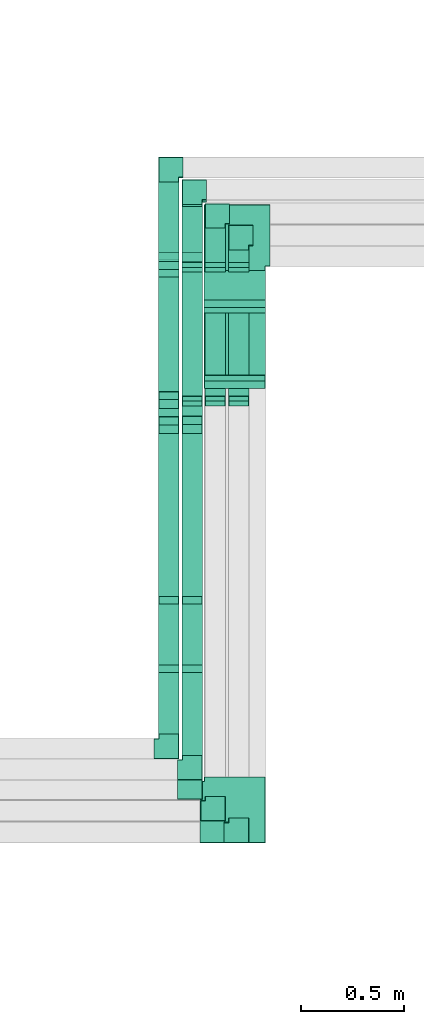
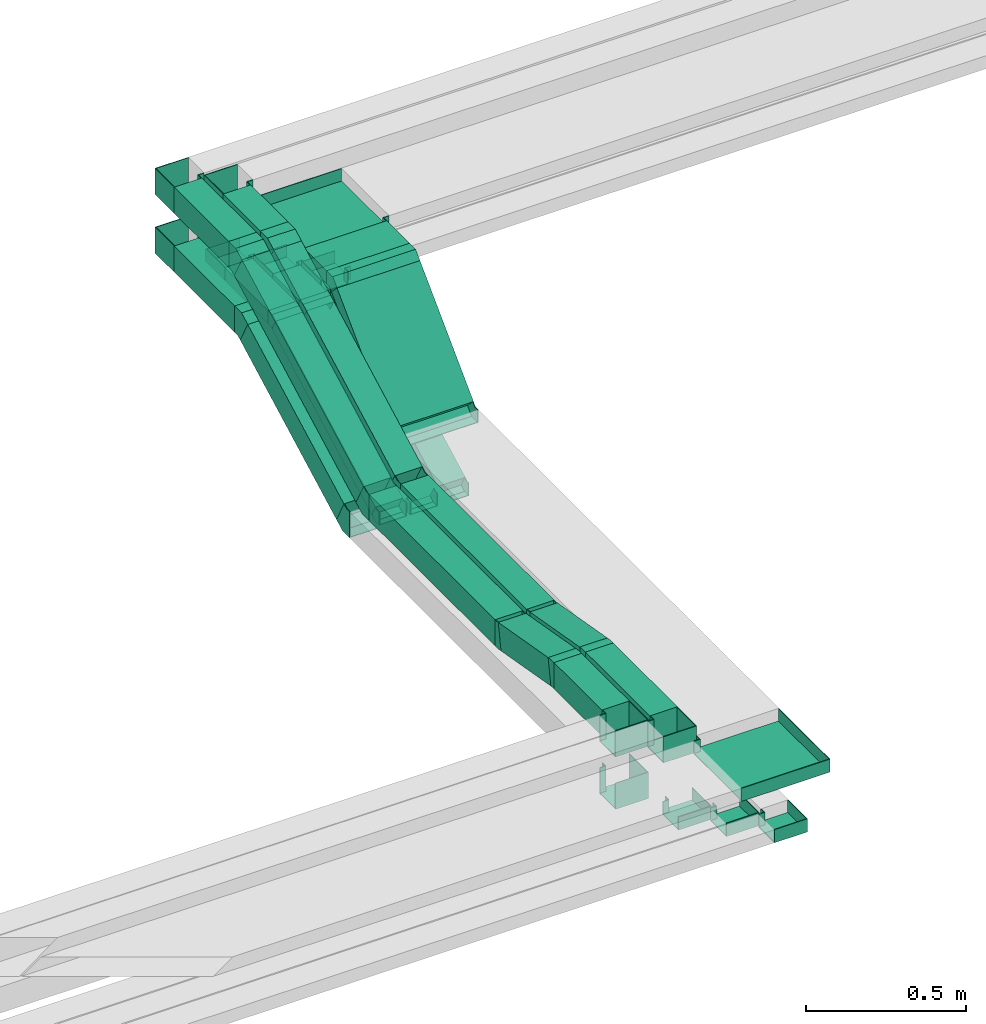
# One storey, part 9 of 14: 32 flow fittings, 20 flow segments.
"""IFC2X3 building model written with IfcOpenShell, lengths in millimetres."""

from ifc_helpers import new_model, entity, si_unit, converted_unit, derived_unit, direction, frame, frame_2d, origin, origin_2d_with_axis, place, context, subcontext, project, spatial, rectangle, extrude, faceted_brep, source, transform, mapped, material, type_object, type_shapes, element, save


model = new_model("IFC2X3")

# Units and contexts
model_context = context("Model", 3, precision=0.01, world=origin(), true_north=direction((6.12303176911189e-17, 1.0)))
body_context = subcontext(model_context, "Body", "Model", "MODEL_VIEW")
ifc_project = project(units=[si_unit("LENGTHUNIT", "METRE", prefix="MILLI"), si_unit("AREAUNIT", "SQUARE_METRE"), si_unit("VOLUMEUNIT", "CUBIC_METRE"), converted_unit("PLANEANGLEUNIT", "DEGREE", entity("IfcRatioMeasure", 0.0174532925199433), si_unit("PLANEANGLEUNIT", "RADIAN"), dimensions=[0, 0, 0, 0, 0, 0, 0]), si_unit("MASSUNIT", "GRAM", prefix="KILO"), derived_unit("MASSDENSITYUNIT", [(si_unit("MASSUNIT", "GRAM", prefix="KILO"), 1), (si_unit("LENGTHUNIT", "METRE"), -3)]), derived_unit("MOMENTOFINERTIAUNIT", [(si_unit("LENGTHUNIT", "METRE"), 4)]), si_unit("TIMEUNIT", "SECOND"), si_unit("FREQUENCYUNIT", "HERTZ"), si_unit("THERMODYNAMICTEMPERATUREUNIT", "DEGREE_CELSIUS"), derived_unit("THERMALTRANSMITTANCEUNIT", [(si_unit("MASSUNIT", "GRAM", prefix="KILO"), 1), (si_unit("THERMODYNAMICTEMPERATUREUNIT", "KELVIN"), -1), (si_unit("TIMEUNIT", "SECOND"), -3)]), derived_unit("VOLUMETRICFLOWRATEUNIT", [(si_unit("LENGTHUNIT", "METRE"), 3), (si_unit("TIMEUNIT", "SECOND"), -1)]), derived_unit("MASSFLOWRATEUNIT", [(si_unit("MASSUNIT", "GRAM", prefix="KILO"), 1), (si_unit("TIMEUNIT", "SECOND"), -1)]), derived_unit("ROTATIONALFREQUENCYUNIT", [(si_unit("TIMEUNIT", "SECOND"), -1)]), si_unit("ELECTRICCURRENTUNIT", "AMPERE"), si_unit("ELECTRICVOLTAGEUNIT", "VOLT"), si_unit("POWERUNIT", "WATT"), si_unit("FORCEUNIT", "NEWTON", prefix="KILO"), si_unit("ILLUMINANCEUNIT", "LUX"), si_unit("LUMINOUSFLUXUNIT", "LUMEN"), si_unit("LUMINOUSINTENSITYUNIT", "CANDELA"), derived_unit("USERDEFINED", [(si_unit("MASSUNIT", "GRAM", prefix="KILO"), -1), (si_unit("LENGTHUNIT", "METRE"), -2), (si_unit("TIMEUNIT", "SECOND"), 3), (si_unit("LUMINOUSFLUXUNIT", "LUMEN"), 1)]), derived_unit("LINEARVELOCITYUNIT", [(si_unit("LENGTHUNIT", "METRE"), 1), (si_unit("TIMEUNIT", "SECOND"), -1)]), si_unit("PRESSUREUNIT", "PASCAL"), derived_unit("USERDEFINED", [(si_unit("LENGTHUNIT", "METRE"), -2), (si_unit("MASSUNIT", "GRAM", prefix="KILO"), 1), (si_unit("TIMEUNIT", "SECOND"), -2)]), derived_unit("LINEARFORCEUNIT", [(si_unit("MASSUNIT", "GRAM", prefix="KILO"), 1), (si_unit("LENGTHUNIT", "METRE"), 1), (si_unit("TIMEUNIT", "SECOND"), -2), (si_unit("LENGTHUNIT", "METRE"), -1)]), derived_unit("PLANARFORCEUNIT", [(si_unit("MASSUNIT", "GRAM", prefix="KILO"), 1), (si_unit("LENGTHUNIT", "METRE"), 1), (si_unit("TIMEUNIT", "SECOND"), -2), (si_unit("LENGTHUNIT", "METRE"), -2)])], contexts=[model_context])

# Site, building, storey
site_placement = place(None, origin())
site = spatial("IfcSite", under=ifc_project, at=site_placement, CompositionType="ELEMENT")
building_placement = place(site_placement, origin())
building = spatial("IfcBuilding", under=site, at=building_placement, CompositionType="ELEMENT")
storey_placement = place(building_placement, frame((0.0, 0.0, 19800.0)))
storey = spatial("IfcBuildingStorey", under=building, at=storey_placement, Name="06", CompositionType="ELEMENT", Elevation=19800.0)

# Flow segments
cable_carrier_segment_type = type_object("IfcCableCarrierSegmentType", PredefinedType="CABLETRAYSEGMENT")
flow_segment_1_placement = place(storey_placement, frame((45595.12, 8738.58, 2760.53)))
element("IfcFlowSegment", 1, at=flow_segment_1_placement, inside=storey, type_object=cable_carrier_segment_type, context=body_context, shape_type="SweptSolid", body=[
    extrude(rectangle(XDim=100.000000000004, YDim=99.9999999999946, at=origin_2d_with_axis()), frame((50.0, 23.5, 44.14), z_axis=(0.0, 0.882701442604095, 0.469934211592058), x_axis=(0.0, -0.469934211592058, 0.882701442604095)), (0.0, 0.0, 1.0), 863.244153807607),
])
flow_segment_2_placement = place(storey_placement, frame((45595.12, 7913.71, 2740.0)))
element("IfcFlowSegment", 2, at=flow_segment_2_placement, inside=storey, type_object=cable_carrier_segment_type, context=body_context, shape_type="SweptSolid", body=[
    extrude(rectangle(XDim=789.605024897989, YDim=99.9999999999946, at=origin_2d_with_axis()), frame((50.0, 394.8, 0.0), z_axis=(0.0, 0.0, 1.0), x_axis=(0.0, 1.0, 0.0)), (0.0, 0.0, 1.0), 100.000000000003),
])
flow_segment_3_placement = place(storey_placement, frame((45595.12, 7564.54, 2743.22)))
element("IfcFlowSegment", 3, at=flow_segment_3_placement, inside=storey, type_object=cable_carrier_segment_type, context=body_context, shape_type="SweptSolid", body=[
    extrude(rectangle(XDim=99.9999999999979, YDim=99.9999999999946, at=origin_2d_with_axis()), frame((50.0, 8.68, 104.31), z_axis=(0.0, 0.984807753012211, -0.173648177666916), x_axis=(0.0, 0.173648177666916, 0.984807753012211)), (0.0, 0.0, 1.0), 317.153609648687),
])
flow_segment_4_placement = place(storey_placement, frame((45595.12, 7245.0, 2800.0)))
element("IfcFlowSegment", 4, at=flow_segment_4_placement, inside=storey, type_object=cable_carrier_segment_type, context=body_context, shape_type="SweptSolid", body=[
    extrude(rectangle(XDim=300.062822927531, YDim=99.9999999999946, at=origin_2d_with_axis()), frame((50.0, 150.03, 0.0), z_axis=(0.0, 0.0, 1.0), x_axis=(0.0, -1.0, 0.0)), (0.0, 0.0, 1.0), 100.000000000003),
])
flow_segment_5_placement = place(storey_placement, frame((45709.29, 8740.22, 2761.4)))
element("IfcFlowSegment", 5, at=flow_segment_5_placement, inside=storey, type_object=cable_carrier_segment_type, context=body_context, shape_type="SweptSolid", body=[
    extrude(rectangle(XDim=100.000000000004, YDim=99.9999999999946, at=origin_2d_with_axis()), frame((50.0, 23.5, 44.14), z_axis=(0.0, 0.882701442604095, 0.469934211592058), x_axis=(0.0, -0.469934211592058, 0.882701442604095)), (0.0, 0.0, 1.0), 859.53337394256),
])
flow_segment_6_placement = place(storey_placement, frame((45709.29, 7913.71, 2740.0)))
element("IfcFlowSegment", 6, at=flow_segment_6_placement, inside=storey, type_object=cable_carrier_segment_type, context=body_context, shape_type="SweptSolid", body=[
    extrude(rectangle(XDim=789.803925423303, YDim=99.9999999999946, at=origin_2d_with_axis()), frame((50.0, 394.9, 0.0), z_axis=(0.0, 0.0, 1.0), x_axis=(0.0, 1.0, 0.0)), (0.0, 0.0, 1.0), 100.000000000003),
])
flow_segment_7_placement = place(storey_placement, frame((45709.29, 7564.54, 2743.22)))
element("IfcFlowSegment", 7, at=flow_segment_7_placement, inside=storey, type_object=cable_carrier_segment_type, context=body_context, shape_type="SweptSolid", body=[
    extrude(rectangle(XDim=99.9999999999979, YDim=99.9999999999946, at=origin_2d_with_axis()), frame((50.0, 8.68, 104.31), z_axis=(0.0, 0.984807753012211, -0.173648177666916), x_axis=(0.0, 0.173648177666916, 0.984807753012211)), (0.0, 0.0, 1.0), 317.153609648693),
])
flow_segment_8_placement = place(storey_placement, frame((45709.29, 7141.93, 2800.0)))
element("IfcFlowSegment", 8, at=flow_segment_8_placement, inside=storey, type_object=cable_carrier_segment_type, context=body_context, shape_type="SweptSolid", body=[
    extrude(rectangle(XDim=403.134642804848, YDim=99.9999999999946, at=origin_2d_with_axis()), frame((50.0, 201.57, 0.0), z_axis=(0.0, 0.0, 1.0), x_axis=(0.0, -1.0, 0.0)), (0.0, 0.0, 1.0), 100.000000000003),
])
flow_segment_9_placement = place(storey_placement, frame((45816.39, 8951.97, 2826.97)))
element("IfcFlowSegment", 9, at=flow_segment_9_placement, inside=storey, type_object=cable_carrier_segment_type, context=body_context, shape_type="SweptSolid", body=[
    extrude(rectangle(XDim=50.0000000000018, YDim=300.000000000001, at=origin_2d_with_axis()), frame((150.0, 17.68, 17.68), z_axis=(-1.65086776189245e-09, 0.707106781186548, 0.707106781186548), x_axis=(1.34656693262509e-09, -0.707106781186548, 0.707106781186548)), (0.0, 0.0, 1.0), 474.766610138279),
])
flow_segment_10_placement = place(storey_placement, frame((45595.12, 9546.18, 2950.0)))
element("IfcFlowSegment", 10, at=flow_segment_10_placement, inside=storey, type_object=cable_carrier_segment_type, context=body_context, shape_type="SweptSolid", body=[
    extrude(rectangle(XDim=378.820559701483, YDim=99.9999999999946, at=origin_2d_with_axis()), frame((50.0, 189.41, 0.0), z_axis=(0.0, 0.0, 1.0), x_axis=(0.0, -1.0, 0.0)), (0.0, 0.0, 1.0), 100.000000000008),
])
flow_segment_11_placement = place(storey_placement, frame((45595.12, 8860.8, 2620.49)))
element("IfcFlowSegment", 11, at=flow_segment_11_placement, inside=storey, type_object=cable_carrier_segment_type, context=body_context, shape_type="SweptSolid", body=[
    extrude(rectangle(XDim=100.000000000004, YDim=99.9999999999946, at=frame_2d((0.0, 0.0), x_axis=(0.0, 1.0))), frame((50.0, 23.47, 44.15), z_axis=(0.0, 0.882947592858917, 0.469471562785909), x_axis=(-1.0, 0.0, 0.0)), (0.0, 0.0, 1.0), 683.160183269278),
])
flow_segment_12_placement = place(storey_placement, frame((45709.29, 9533.71, 2950.0)))
element("IfcFlowSegment", 12, at=flow_segment_12_placement, inside=storey, type_object=cable_carrier_segment_type, context=body_context, shape_type="SweptSolid", body=[
    extrude(rectangle(XDim=271.286959843684, YDim=99.9999999999946, at=origin_2d_with_axis()), frame((50.0, 135.64, 0.0), z_axis=(0.0, 0.0, 1.0), x_axis=(0.0, 1.0, 0.0)), (0.0, 0.0, 1.0), 49.9999999999973),
])
flow_segment_13_placement = place(storey_placement, frame((45709.29, 8861.53, 2611.71)))
element("IfcFlowSegment", 13, at=flow_segment_13_placement, inside=storey, type_object=cable_carrier_segment_type, context=body_context, shape_type="SweptSolid", body=[
    extrude(rectangle(XDim=49.9999999999982, YDim=708.092983553467, at=frame_2d((0.0, 0.0), x_axis=(0.0, 1.0))), frame((0.0, 324.34, 188.29), z_axis=(1.0, 0.0, 0.0), x_axis=(0.0, 0.882947592858905, 0.469471562785931)), (0.0, 0.0, 1.0), 99.9999999999946),
])
flow_segment_14_placement = place(storey_placement, frame((45821.5, 8861.53, 2611.71)))
element("IfcFlowSegment", 14, at=flow_segment_14_placement, inside=storey, type_object=cable_carrier_segment_type, context=body_context, shape_type="SweptSolid", body=[
    extrude(rectangle(XDim=49.9999999999971, YDim=708.092983553457, at=frame_2d((0.0, 0.0), x_axis=(0.0, 1.0))), frame((0.0, 324.34, 188.29), z_axis=(1.0, 0.0, 0.0), x_axis=(0.0, 0.882947592858912, 0.46947156278592)), (0.0, 0.0, 1.0), 99.9999999999945),
])
flow_segment_15_placement = place(storey_placement, frame((45821.5, 9533.71, 2950.0)))
element("IfcFlowSegment", 15, at=flow_segment_15_placement, inside=storey, type_object=cable_carrier_segment_type, context=body_context, shape_type="SweptSolid", body=[
    extrude(rectangle(XDim=166.286959843394, YDim=99.9999999999946, at=origin_2d_with_axis()), frame((50.0, 83.14, 0.0), z_axis=(0.0, 0.0, 1.0), x_axis=(0.0, -1.0, 0.0)), (0.0, 0.0, 1.0), 50.0000000000016),
])
flow_segment_16_placement = place(storey_placement, frame((45934.76, 8861.53, 2611.71)))
element("IfcFlowSegment", 16, at=flow_segment_16_placement, inside=storey, type_object=cable_carrier_segment_type, context=body_context, shape_type="SweptSolid", body=[
    extrude(rectangle(XDim=49.9999999999977, YDim=708.09298355346, at=frame_2d((0.0, 0.0), x_axis=(0.0, 1.0))), frame((0.0, 324.34, 188.29), z_axis=(1.0, 0.0, 0.0), x_axis=(0.0, 0.882947592858916, 0.469471562785912)), (0.0, 0.0, 1.0), 99.9999999999946),
])
flow_segment_17_placement = place(storey_placement, frame((45934.76, 9533.71, 2950.0)))
element("IfcFlowSegment", 17, at=flow_segment_17_placement, inside=storey, type_object=cable_carrier_segment_type, context=body_context, shape_type="SweptSolid", body=[
    extrude(rectangle(XDim=61.2869598436415, YDim=99.9999999999946, at=origin_2d_with_axis()), frame((50.0, 30.64, 0.0), z_axis=(0.0, 0.0, 1.0), x_axis=(0.0, -1.0, 0.0)), (0.0, 0.0, 1.0), 49.9999999999973),
])
flow_segment_18_placement = place(storey_placement, frame((45595.12, 9582.82, 3175.0)))
element("IfcFlowSegment", 18, at=flow_segment_18_placement, inside=storey, type_object=cable_carrier_segment_type, context=body_context, shape_type="SweptSolid", body=[
    extrude(rectangle(XDim=342.182647756361, YDim=99.9999999999946, at=origin_2d_with_axis()), frame((50.0, 171.09, 0.0), z_axis=(0.0, 0.0, 1.0), x_axis=(0.0, -1.0, 0.0)), (0.0, 0.0, 1.0), 100.000000000003),
])
flow_segment_19_placement = place(storey_placement, frame((45709.29, 9582.62, 3175.0)))
element("IfcFlowSegment", 19, at=flow_segment_19_placement, inside=storey, type_object=cable_carrier_segment_type, context=body_context, shape_type="SweptSolid", body=[
    extrude(rectangle(XDim=233.381537551787, YDim=99.9999999999946, at=origin_2d_with_axis()), frame((50.0, 116.69, 0.0), z_axis=(0.0, -2.93187893227309e-09, 1.0), x_axis=(-1.08328686606349e-09, -1.0, -2.93187893227309e-09)), (0.0, 0.0, 1.0), 100.000000000008),
])
flow_segment_20_placement = place(storey_placement, frame((45816.39, 9352.78, 3175.0)))
element("IfcFlowSegment", 20, at=flow_segment_20_placement, inside=storey, type_object=cable_carrier_segment_type, context=body_context, shape_type="SweptSolid", body=[
    extrude(rectangle(XDim=142.218253660418, YDim=300.000000000001, at=origin_2d_with_axis()), frame((150.0, 71.11, 0.0), z_axis=(0.0, 1.26959697066353e-08, 1.0), x_axis=(0.0, -1.0, 1.26959697066353e-08)), (0.0, 0.0, 1.0), 49.9999999999973),
])

# Flow fittings
ifc_material = material()
cable_carrier_fitting_type_1 = type_object("IfcCableCarrierFittingType", Name="ADSK_ _ :", PredefinedType="NOTDEFINED", material=ifc_material)
shared_shape_1 = source(origin(), body_context, "Body", "Brep", [
    faceted_brep([(-70.0, 50.0, -25.0), (-70.0, -50.0, -25.0), (-70.0, -50.0, 25.0), (-70.0, -47.46, 25.0), (-70.0, -47.46, -22.46), (-70.0, 47.46, -22.46), (-70.0, 47.46, 25.0), (-70.0, 50.0, 25.0), (-50.0, 50.0, -25.0), (-50.0, 70.0, -25.0), (50.0, 70.0, -25.0), (50.0, -50.0, -25.0), (50.0, -50.0, 25.0), (50.0, 70.0, 25.0), (47.46, 70.0, 25.0), (47.46, -47.46, 25.0), (47.46, -47.46, -22.46), (47.46, 70.0, -22.46), (-47.46, 70.0, -22.46), (-47.46, 47.46, -22.46), (-47.46, 47.46, 25.0), (-47.46, 70.0, 25.0), (-50.0, 70.0, 25.0), (-50.0, 50.0, 25.0)], [[[0, 1, 2, 3, 4, 5, 6, 7]], [[1, 0, 8, 9, 10, 11]], [[2, 1, 11, 12]], [[3, 2, 12, 13, 14, 15]], [[4, 3, 15, 16]], [[5, 4, 16, 17, 18, 19]], [[6, 5, 19, 20]], [[7, 6, 20, 21, 22, 23]], [[0, 7, 23, 8]], [[9, 22, 21, 18, 17, 14, 13, 10]], [[12, 11, 10, 13]], [[16, 15, 14, 17]], [[20, 19, 18, 21]], [[8, 23, 22, 9]]]),
])
type_shapes(cable_carrier_fitting_type_1, [shared_shape_1])
flow_fitting_1_placement = place(storey_placement, frame((45759.29, 9875.0, 2975.0), z_axis=(0.0, 0.0, 1.0), x_axis=(-1.0, 0.0, 0.0)))
element("IfcFlowFitting", 21, at=flow_fitting_1_placement, inside=storey, type_object=cable_carrier_fitting_type_1, material=ifc_material, Name="ADSK_ _ :", ObjectType="ADSK_ _ :", context=body_context, shape_type="MappedRepresentation", body=[
    mapped(shared_shape_1, transform((0.0, 0.0, 0.0), scale=1.0)),
])
for number, where, name in (
    (22, (45759.29, 6977.78, 2625.0), "ADSK_ _ :"),
    (23, (45871.5, 6872.78, 2625.0), "ADSK_ _ :"),
):
    element("IfcFlowFitting", number, at=place(storey_placement, frame(where)), inside=storey, type_object=cable_carrier_fitting_type_1, material=ifc_material, Name=name, ObjectType="ADSK_ _ :", context=body_context, shape_type="MappedRepresentation", body=[
        mapped(shared_shape_1, transform((0.0, 0.0, 0.0), scale=1.0)),
    ])
flow_fitting_2_placement = place(storey_placement, frame((45871.5, 9770.0, 2975.0), z_axis=(0.0, 0.0, 1.0), x_axis=(-1.0, 0.0, 0.0)))
element("IfcFlowFitting", 24, at=flow_fitting_2_placement, inside=storey, type_object=cable_carrier_fitting_type_1, material=ifc_material, Name="ADSK_ _ :", ObjectType="ADSK_ _ :", context=body_context, shape_type="MappedRepresentation", body=[
    mapped(shared_shape_1, transform((0.0, 0.0, 0.0), scale=1.0)),
])
flow_fitting_3_placement = place(storey_placement, frame((45984.76, 6767.78, 2625.0)))
element("IfcFlowFitting", 25, at=flow_fitting_3_placement, inside=storey, type_object=cable_carrier_fitting_type_1, material=ifc_material, Name="ADSK_ _ :", ObjectType="ADSK_ _ :", context=body_context, shape_type="MappedRepresentation", body=[
    mapped(shared_shape_1, transform((0.0, 0.0, 0.0), scale=1.0)),
])
flow_fitting_4_placement = place(storey_placement, frame((45984.76, 9665.0, 2975.0), z_axis=(0.0, 0.0, 1.0), x_axis=(-1.0, 0.0, 0.0)))
element("IfcFlowFitting", 26, at=flow_fitting_4_placement, inside=storey, type_object=cable_carrier_fitting_type_1, material=ifc_material, Name="ADSK_ _ :", ObjectType="ADSK_ _ :", context=body_context, shape_type="MappedRepresentation", body=[
    mapped(shared_shape_1, transform((0.0, 0.0, 0.0), scale=1.0)),
])
cable_carrier_fitting_type_2 = type_object("IfcCableCarrierFittingType", Name="ADSK_ _ :", PredefinedType="NOTDEFINED", material=ifc_material)
shared_shape_2 = source(origin(), body_context, "Body", "Brep", [
    faceted_brep([(-170.0, 150.0, -25.0), (-170.0, -150.0, -25.0), (-170.0, -150.0, 25.0), (-170.0, -147.46, 25.0), (-170.0, -147.46, -22.46), (-170.0, 147.46, -22.46), (-170.0, 147.46, 25.0), (-170.0, 150.0, 25.0), (-150.0, 150.0, -25.0), (-150.0, 170.0, -25.0), (150.0, 170.0, -25.0), (150.0, -150.0, -25.0), (150.0, -150.0, 25.0), (150.0, 170.0, 25.0), (147.46, 170.0, 25.0), (147.46, -147.46, 25.0), (147.46, -147.46, -22.46), (147.46, 170.0, -22.46), (-147.46, 170.0, -22.46), (-147.46, 147.46, -22.46), (-147.46, 147.46, 25.0), (-147.46, 170.0, 25.0), (-150.0, 170.0, 25.0), (-150.0, 150.0, 25.0)], [[[0, 1, 2, 3, 4, 5, 6, 7]], [[1, 0, 8, 9, 10, 11]], [[2, 1, 11, 12]], [[3, 2, 12, 13, 14, 15]], [[4, 3, 15, 16]], [[5, 4, 16, 17, 18, 19]], [[6, 5, 19, 20]], [[7, 6, 20, 21, 22, 23]], [[0, 7, 23, 8]], [[9, 22, 21, 18, 17, 14, 13, 10]], [[12, 11, 10, 13]], [[16, 15, 14, 17]], [[20, 19, 18, 21]], [[8, 23, 22, 9]]]),
])
type_shapes(cable_carrier_fitting_type_2, [shared_shape_2])
flow_fitting_5_placement = place(storey_placement, frame((45966.39, 9665.0, 3200.0), z_axis=(0.0, 0.0, 1.0), x_axis=(-1.0, 0.0, 0.0)))
element("IfcFlowFitting", 27, at=flow_fitting_5_placement, inside=storey, type_object=cable_carrier_fitting_type_2, material=ifc_material, Name="ADSK_ _ :", ObjectType="ADSK_ _ :", context=body_context, shape_type="MappedRepresentation", body=[
    mapped(shared_shape_2, transform((0.0, 0.0, 0.0), scale=1.0)),
])
flow_fitting_6_placement = place(storey_placement, frame((45966.39, 6867.78, 2825.0)))
element("IfcFlowFitting", 28, at=flow_fitting_6_placement, inside=storey, type_object=cable_carrier_fitting_type_2, material=ifc_material, Name="ADSK_ _ :", ObjectType="ADSK_ _ :", context=body_context, shape_type="MappedRepresentation", body=[
    mapped(shared_shape_2, transform((0.0, 0.0, 0.0), scale=1.0)),
])
cable_carrier_fitting_type_3 = type_object("IfcCableCarrierFittingType", Name="ADSK_ _ :", PredefinedType="NOTDEFINED", material=ifc_material)
shared_shape_3 = source(origin(), body_context, "Body", "Brep", [
    faceted_brep([(-70.0, 50.0, -50.0), (-70.0, -50.0, -50.0), (-70.0, -50.0, 50.0), (-70.0, -47.46, 50.0), (-70.0, -47.46, -47.46), (-70.0, 47.46, -47.46), (-70.0, 47.46, 50.0), (-70.0, 50.0, 50.0), (-50.0, 50.0, -50.0), (-50.0, 70.0, -50.0), (50.0, 70.0, -50.0), (50.0, -50.0, -50.0), (50.0, -50.0, 50.0), (50.0, 70.0, 50.0), (47.46, 70.0, 50.0), (47.46, -47.46, 50.0), (47.46, -47.46, -47.46), (47.46, 70.0, -47.46), (-47.46, 70.0, -47.46), (-47.46, 47.46, -47.46), (-47.46, 47.46, 50.0), (-47.46, 70.0, 50.0), (-50.0, 70.0, 50.0), (-50.0, 50.0, 50.0)], [[[0, 1, 2, 3, 4, 5, 6, 7]], [[1, 0, 8, 9, 10, 11]], [[2, 1, 11, 12]], [[3, 2, 12, 13, 14, 15]], [[4, 3, 15, 16]], [[5, 4, 16, 17, 18, 19]], [[6, 5, 19, 20]], [[7, 6, 20, 21, 22, 23]], [[0, 7, 23, 8]], [[9, 22, 21, 18, 17, 14, 13, 10]], [[12, 11, 10, 13]], [[16, 15, 14, 17]], [[20, 19, 18, 21]], [[8, 23, 22, 9]]]),
])
type_shapes(cable_carrier_fitting_type_3, [shared_shape_3])
for number, where, name in (
    (29, (45645.12, 7175.0, 2650.0), "ADSK_ _ :"),
    (30, (45759.29, 7071.93, 2850.0), "ADSK_ _ :"),
    (31, (45645.12, 7175.0, 2850.0), "ADSK_ _ :"),
):
    element("IfcFlowFitting", number, at=place(storey_placement, frame(where)), inside=storey, type_object=cable_carrier_fitting_type_3, material=ifc_material, Name=name, ObjectType="ADSK_ _ :", context=body_context, shape_type="MappedRepresentation", body=[
        mapped(shared_shape_3, transform((0.0, 0.0, 0.0), scale=1.0)),
    ])
for number, where, z_axis, x_axis, name in (
    (32, (45645.12, 9995.0, 3000.0), (0.0, 0.0, 1.0), (-1.0, 0.0, 0.0), "ADSK_ _ :"),
    (33, (45645.12, 9995.0, 3225.0), (0.0, 0.0, 1.0), (-1.0, 0.0, 0.0), "ADSK_ _ :"),
    (34, (45759.29, 9886.0, 3225.0), (0.0, 0.0, 1.0), (-1.0, 0.0, 0.0), "ADSK_ _ :"),
):
    element("IfcFlowFitting", number, at=place(storey_placement, frame(where, z_axis=z_axis, x_axis=x_axis)), inside=storey, type_object=cable_carrier_fitting_type_3, material=ifc_material, Name=name, ObjectType="ADSK_ _ :", context=body_context, shape_type="MappedRepresentation", body=[
        mapped(shared_shape_3, transform((0.0, 0.0, 0.0), scale=1.0)),
    ])
cable_carrier_fitting_type_4 = type_object("IfcCableCarrierFittingType", PredefinedType="NOTDEFINED", material=ifc_material)
shared_shape_4 = source(origin(), body_context, "Body", "Brep", [
    faceted_brep([(-14.19, -50.0, 50.0), (-14.19, 50.0, 50.0), (-14.19, 50.0, 47.46), (-14.19, -47.46, 47.46), (-14.19, -47.46, -47.46), (-14.19, 50.0, -47.46), (-14.19, 50.0, -50.0), (-14.19, -50.0, -50.0), (22.65, -46.78, 50.0), (22.65, -46.78, -50.0), (5.29, 51.7, -50.0), (5.29, 51.7, -47.46), (22.21, -44.28, -47.46), (22.21, -44.28, 47.46), (5.29, 51.7, 47.46), (5.29, 51.7, 50.0), (4.37, -50.0, 50.0), (-4.37, 50.0, 50.0), (-4.37, 50.0, 47.46), (4.15, -47.46, 47.46), (4.15, -47.46, -47.46), (-4.37, 50.0, -47.46), (-4.37, 50.0, -50.0), (4.37, -50.0, -50.0)], [[[0, 1, 2, 3, 4, 5, 6, 7]], [[8, 9, 10, 11, 12, 13, 14, 15]], [[1, 0, 16, 8, 15, 17]], [[2, 1, 17, 18]], [[3, 2, 18, 14, 13, 19]], [[4, 3, 19, 20]], [[5, 4, 20, 12, 11, 21]], [[6, 5, 21, 22]], [[7, 6, 22, 10, 9, 23]], [[0, 7, 23, 16]], [[18, 17, 15, 14]], [[20, 19, 13, 12]], [[22, 21, 11, 10]], [[16, 23, 9, 8]]]),
])
type_shapes(cable_carrier_fitting_type_4, [shared_shape_4])
for number, where, z_axis, x_axis in (
    (35, (45645.12, 7899.53, 2790.0), (-1.0, 0.0, 0.0), (0.0, -1.0, 0.0)),
    (36, (45645.12, 7559.25, 2850.0), (1.0, 0.0, 0.0), (0.0, -0.984807753012209, 0.173648177666924)),
    (37, (45759.29, 7899.53, 2790.0), (-1.0, 0.0, 0.0), (0.0, -1.0, 0.0)),
    (38, (45759.29, 7559.25, 2850.0), (1.0, 0.0, 0.0), (0.0, -0.984807753012209, 0.173648177666924)),
):
    element("IfcFlowFitting", number, at=place(storey_placement, frame(where, z_axis=z_axis, x_axis=x_axis)), inside=storey, type_object=cable_carrier_fitting_type_4, material=ifc_material, context=body_context, shape_type="MappedRepresentation", body=[
        mapped(shared_shape_4, transform((0.0, 0.0, 0.0), scale=1.0)),
    ])
cable_carrier_fitting_type_5 = type_object("IfcCableCarrierFittingType", PredefinedType="NOTDEFINED", material=ifc_material)
shared_shape_5 = source(origin(), body_context, "Body", "Brep", [
    faceted_brep([(-27.78, -25.0, 150.0), (-27.78, 25.0, 150.0), (-27.78, 25.0, 147.46), (-27.78, -22.46, 147.46), (-27.78, -22.46, -147.46), (-27.78, 25.0, -147.46), (-27.78, 25.0, -150.0), (-27.78, -25.0, -150.0), (37.32, 1.97, 150.0), (37.32, 1.97, -150.0), (1.97, 37.32, -150.0), (1.97, 37.32, -147.46), (35.53, 3.76, -147.46), (35.53, 3.76, 147.46), (1.97, 37.32, 147.46), (1.97, 37.32, 150.0), (10.36, -25.0, 150.0), (-10.36, 25.0, 150.0), (-10.36, 25.0, 147.46), (9.3, -22.46, 147.46), (9.3, -22.46, -147.46), (-10.36, 25.0, -147.46), (-10.36, 25.0, -150.0), (10.36, -25.0, -150.0)], [[[0, 1, 2, 3, 4, 5, 6, 7]], [[8, 9, 10, 11, 12, 13, 14, 15]], [[1, 0, 16, 8, 15, 17]], [[2, 1, 17, 18]], [[3, 2, 18, 14, 13, 19]], [[4, 3, 19, 20]], [[5, 4, 20, 12, 11, 21]], [[6, 5, 21, 22]], [[7, 6, 22, 10, 9, 23]], [[0, 7, 23, 16]], [[18, 17, 15, 14]], [[20, 19, 13, 12]], [[22, 21, 11, 10]], [[16, 23, 9, 8]]]),
])
type_shapes(cable_carrier_fitting_type_5, [shared_shape_5])
flow_fitting_7_placement = place(storey_placement, frame((45966.39, 9325.0, 3200.0), z_axis=(1.0, 0.0, 0.0), x_axis=(0.0, -1.0, 1.26959618933866e-08)))
element("IfcFlowFitting", 39, at=flow_fitting_7_placement, inside=storey, type_object=cable_carrier_fitting_type_5, material=ifc_material, context=body_context, shape_type="MappedRepresentation", body=[
    mapped(shared_shape_5, transform((0.0, 0.0, 0.0), scale=1.0)),
])
cable_carrier_fitting_type_6 = type_object("IfcCableCarrierFittingType", PredefinedType="NOTDEFINED", material=ifc_material)
type_shapes(cable_carrier_fitting_type_6, [shared_shape_5])
flow_fitting_8_placement = place(storey_placement, frame((45966.39, 8950.0, 2825.0), z_axis=(-1.0, 0.0, 0.0), x_axis=(0.0, -0.707106781186535, -0.70710678118656)))
element("IfcFlowFitting", 40, at=flow_fitting_8_placement, inside=storey, type_object=cable_carrier_fitting_type_6, material=ifc_material, context=body_context, shape_type="MappedRepresentation", body=[
    mapped(shared_shape_5, transform((0.0, 0.0, 0.0), scale=1.0)),
])
cable_carrier_fitting_type_7 = type_object("IfcCableCarrierFittingType", PredefinedType="NOTDEFINED", material=ifc_material)
shared_shape_6 = source(origin(), body_context, "Body", "Brep", [
    faceted_brep([(-31.18, -50.0, 50.0), (-31.18, 50.0, 50.0), (-31.18, 50.0, 47.46), (-31.18, -47.46, 47.46), (-31.18, -47.46, -47.46), (-31.18, 50.0, -47.46), (-31.18, 50.0, -50.0), (-31.18, -50.0, -50.0), (51.0, -29.51, 50.0), (51.0, -29.51, -50.0), (4.06, 58.79, -50.0), (4.06, 58.79, -47.46), (49.81, -27.27, -47.46), (49.81, -27.27, 47.46), (4.06, 58.79, 47.46), (4.06, 58.79, 50.0), (12.47, -50.0, 50.0), (-12.47, 50.0, 50.0), (-12.47, 50.0, 47.46), (11.83, -47.46, 47.46), (11.83, -47.46, -47.46), (-12.47, 50.0, -47.46), (-12.47, 50.0, -50.0), (12.47, -50.0, -50.0)], [[[0, 1, 2, 3, 4, 5, 6, 7]], [[8, 9, 10, 11, 12, 13, 14, 15]], [[1, 0, 16, 8, 15, 17]], [[2, 1, 17, 18]], [[3, 2, 18, 14, 13, 19]], [[4, 3, 19, 20]], [[5, 4, 20, 12, 11, 21]], [[6, 5, 21, 22]], [[7, 6, 22, 10, 9, 23]], [[0, 7, 23, 16]], [[18, 17, 15, 14]], [[20, 19, 13, 12]], [[22, 21, 11, 10]], [[16, 23, 9, 8]]]),
])
type_shapes(cable_carrier_fitting_type_7, [shared_shape_6])
for number, where, z_axis, x_axis in (
    (41, (45645.12, 8856.75, 2650.0), (1.0, 0.0, 0.0), (0.0, 1.0, 0.0)),
    (42, (45645.12, 9515.0, 3000.0), (1.0, 0.0, 0.0), (0.0, -1.0, 0.0)),
):
    element("IfcFlowFitting", number, at=place(storey_placement, frame(where, z_axis=z_axis, x_axis=x_axis)), inside=storey, type_object=cable_carrier_fitting_type_7, material=ifc_material, context=body_context, shape_type="MappedRepresentation", body=[
        mapped(shared_shape_6, transform((0.0, 0.0, 0.0), scale=1.0)),
    ])
cable_carrier_fitting_type_8 = type_object("IfcCableCarrierFittingType", PredefinedType="NOTDEFINED", material=ifc_material)
shared_shape_7 = source(origin(), body_context, "Body", "Brep", [
    faceted_brep([(-18.71, -25.0, 50.0), (-18.71, 25.0, 50.0), (-18.71, 25.0, 47.46), (-18.71, -22.46, 47.46), (-18.71, -22.46, -47.46), (-18.71, 25.0, -47.46), (-18.71, 25.0, -50.0), (-18.71, -25.0, -50.0), (28.26, -13.29, 50.0), (28.26, -13.29, -50.0), (4.79, 30.86, -50.0), (4.79, 30.86, -47.46), (27.07, -11.05, -47.46), (27.07, -11.05, 47.46), (4.79, 30.86, 47.46), (4.79, 30.86, 50.0), (6.23, -25.0, 50.0), (-6.23, 25.0, 50.0), (-6.23, 25.0, 47.46), (5.6, -22.46, 47.46), (5.6, -22.46, -47.46), (-6.23, 25.0, -47.46), (-6.23, 25.0, -50.0), (6.23, -25.0, -50.0)], [[[0, 1, 2, 3, 4, 5, 6, 7]], [[8, 9, 10, 11, 12, 13, 14, 15]], [[1, 0, 16, 8, 15, 17]], [[2, 1, 17, 18]], [[3, 2, 18, 14, 13, 19]], [[4, 3, 19, 20]], [[5, 4, 20, 12, 11, 21]], [[6, 5, 21, 22]], [[7, 6, 22, 10, 9, 23]], [[0, 7, 23, 16]], [[18, 17, 15, 14]], [[20, 19, 13, 12]], [[22, 21, 11, 10]], [[16, 23, 9, 8]]]),
])
type_shapes(cable_carrier_fitting_type_8, [shared_shape_7])
for number, where, z_axis, x_axis in (
    (43, (45759.29, 9515.0, 2975.0), (-1.0, 0.0, 0.0), (0.0, 0.882947592858903, 0.469471562785936)),
    (44, (45759.29, 8856.75, 2625.0), (-1.0, 0.0, 0.0), (0.0, -0.882947592858904, -0.469471562785934)),
    (45, (45871.5, 8856.75, 2625.0), (-1.0, 0.0, 0.0), (0.0, -0.882947592858907, -0.469471562785928)),
    (46, (45871.5, 9515.0, 2975.0), (-1.0, 0.0, 0.0), (0.0, 0.88294759285891, 0.469471562785922)),
    (47, (45984.76, 8856.75, 2625.0), (-1.0, 0.0, 0.0), (0.0, -0.882947592858912, -0.469471562785918)),
    (48, (45984.76, 9515.0, 2975.0), (-1.0, 0.0, 0.0), (0.0, 0.882947592858915, 0.469471562785914)),
):
    element("IfcFlowFitting", number, at=place(storey_placement, frame(where, z_axis=z_axis, x_axis=x_axis)), inside=storey, type_object=cable_carrier_fitting_type_8, material=ifc_material, context=body_context, shape_type="MappedRepresentation", body=[
        mapped(shared_shape_7, transform((0.0, 0.0, 0.0), scale=1.0)),
    ])
cable_carrier_fitting_type_9 = type_object("IfcCableCarrierFittingType", PredefinedType="NOTDEFINED", material=ifc_material)
shared_shape_8 = source(origin(), body_context, "Body", "Brep", [
    faceted_brep([(-31.21, -50.0, 50.0), (-31.21, 50.0, 50.0), (-31.21, 50.0, 47.46), (-31.21, -47.46, 47.46), (-31.21, -47.46, -47.46), (-31.21, 50.0, -47.46), (-31.21, 50.0, -50.0), (-31.21, -50.0, -50.0), (51.04, -29.47, 50.0), (51.04, -29.47, -50.0), (4.05, 58.8, -50.0), (4.05, 58.8, -47.46), (49.85, -27.23, -47.46), (49.85, -27.23, 47.46), (4.05, 58.8, 47.46), (4.05, 58.8, 50.0), (12.48, -50.0, 50.0), (-12.48, 50.0, 50.0), (-12.48, 50.0, 47.46), (11.85, -47.46, 47.46), (11.85, -47.46, -47.46), (-12.48, 50.0, -47.46), (-12.48, 50.0, -50.0), (12.48, -50.0, -50.0)], [[[0, 1, 2, 3, 4, 5, 6, 7]], [[8, 9, 10, 11, 12, 13, 14, 15]], [[1, 0, 16, 8, 15, 17]], [[2, 1, 17, 18]], [[3, 2, 18, 14, 13, 19]], [[4, 3, 19, 20]], [[5, 4, 20, 12, 11, 21]], [[6, 5, 21, 22]], [[7, 6, 22, 10, 9, 23]], [[0, 7, 23, 16]], [[18, 17, 15, 14]], [[20, 19, 13, 12]], [[22, 21, 11, 10]], [[16, 23, 9, 8]]]),
])
type_shapes(cable_carrier_fitting_type_9, [shared_shape_8])
for number, where, z_axis, x_axis in (
    (49, (45645.12, 9551.61, 3225.0), (1.0, 0.0, 0.0), (0.0, -1.0, 0.0)),
    (50, (45645.12, 8734.53, 2790.0), (1.0, 0.0, 0.0), (0.0, 1.0, 0.0)),
):
    element("IfcFlowFitting", number, at=place(storey_placement, frame(where, z_axis=z_axis, x_axis=x_axis)), inside=storey, type_object=cable_carrier_fitting_type_9, material=ifc_material, context=body_context, shape_type="MappedRepresentation", body=[
        mapped(shared_shape_8, transform((0.0, 0.0, 0.0), scale=1.0)),
    ])
cable_carrier_fitting_type_10 = type_object("IfcCableCarrierFittingType", PredefinedType="NOTDEFINED", material=ifc_material)
shared_shape_9 = source(origin(), body_context, "Body", "Brep", [
    faceted_brep([(-32.1, -50.0, 50.0), (-32.1, 50.0, 50.0), (-32.1, 50.0, 47.46), (-32.1, -47.46, 47.46), (-32.1, -47.46, -47.46), (-32.1, 50.0, -47.46), (-32.1, 50.0, -50.0), (-32.1, -50.0, -50.0), (52.29, -28.22, 50.0), (52.29, -28.22, -50.0), (3.89, 59.29, -50.0), (3.89, 59.29, -47.46), (51.06, -25.99, -47.46), (51.06, -25.99, 47.46), (3.89, 59.29, 47.46), (3.89, 59.29, 50.0), (12.91, -50.0, 50.0), (-12.91, 50.0, 50.0), (-12.91, 50.0, 47.46), (12.25, -47.46, 47.46), (12.25, -47.46, -47.46), (-12.91, 50.0, -47.46), (-12.91, 50.0, -50.0), (12.91, -50.0, -50.0)], [[[0, 1, 2, 3, 4, 5, 6, 7]], [[8, 9, 10, 11, 12, 13, 14, 15]], [[1, 0, 16, 8, 15, 17]], [[2, 1, 17, 18]], [[3, 2, 18, 14, 13, 19]], [[4, 3, 19, 20]], [[5, 4, 20, 12, 11, 21]], [[6, 5, 21, 22]], [[7, 6, 22, 10, 9, 23]], [[0, 7, 23, 16]], [[18, 17, 15, 14]], [[20, 19, 13, 12]], [[22, 21, 11, 10]], [[16, 23, 9, 8]]]),
])
type_shapes(cable_carrier_fitting_type_10, [shared_shape_9])
for number, where, z_axis, x_axis in (
    (51, (45759.29, 9550.52, 3225.0), (1.0, 0.0, 0.0), (0.0, -1.0, 0.0)),
    (52, (45759.29, 8735.62, 2790.0), (1.0, 0.0, 0.0), (0.0, 1.0, 0.0)),
):
    element("IfcFlowFitting", number, at=place(storey_placement, frame(where, z_axis=z_axis, x_axis=x_axis)), inside=storey, type_object=cable_carrier_fitting_type_10, material=ifc_material, context=body_context, shape_type="MappedRepresentation", body=[
        mapped(shared_shape_9, transform((0.0, 0.0, 0.0), scale=1.0)),
    ])

save(model, "model.ifc")
